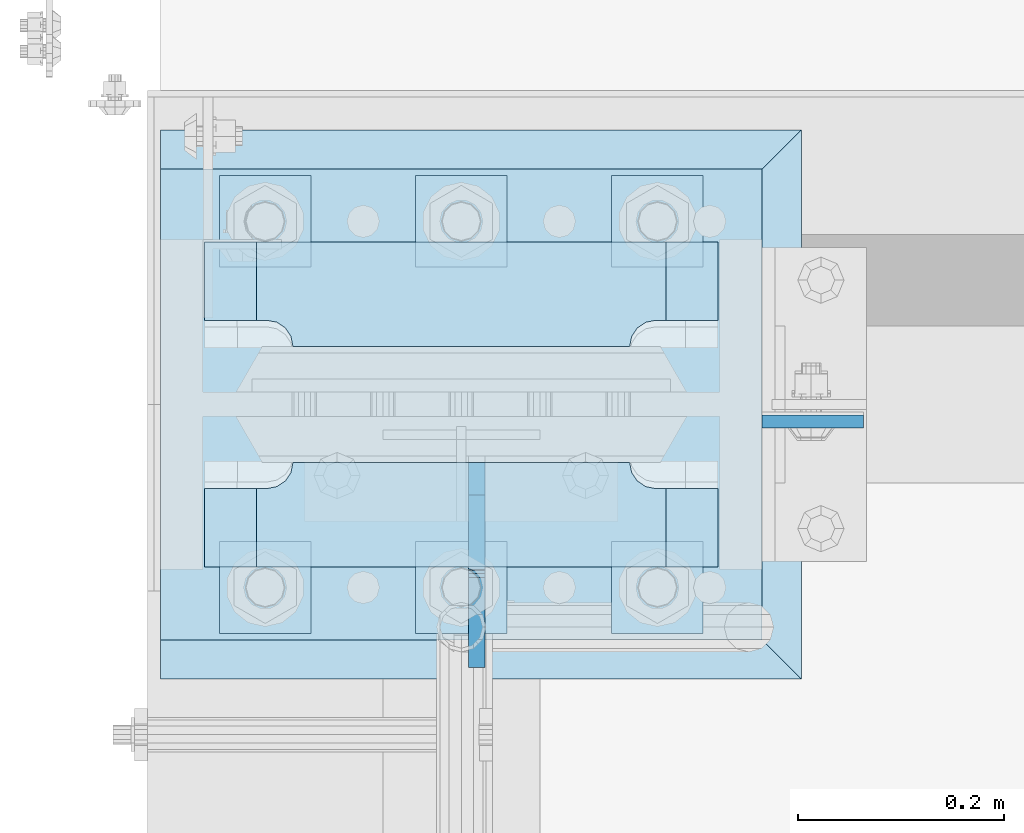
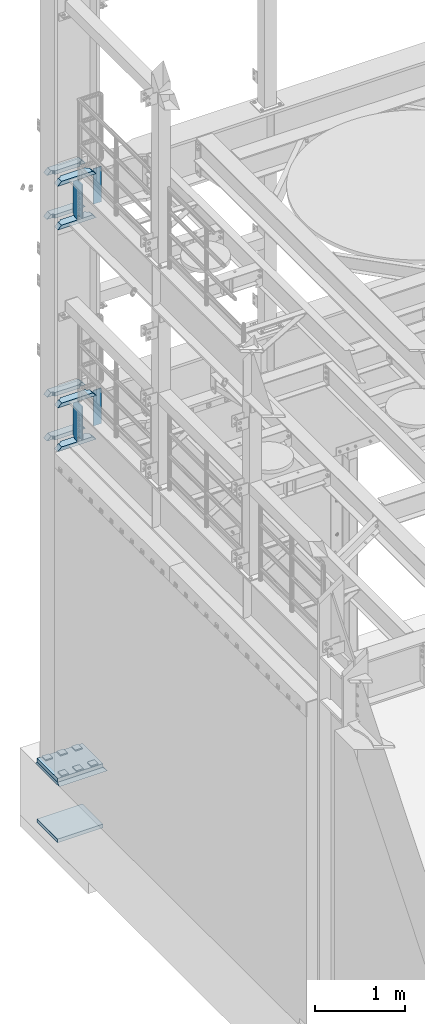
# One storey, part 1773 of 1876: 21 plates, 3 elements without a shape of their own.
"""IFC2X3 building model written with IfcOpenShell, lengths in millimetres."""

from ifc_helpers import new_model, si_unit, frame, origin_with_axes, place, context, subcontext, project, spatial, faceted_brep, material, type_object, element, aggregate, save


model = new_model("IFC2X3")

# Units and contexts
model_context = context("Model", 3, precision=1e-05, world=origin_with_axes())
body_context = subcontext(model_context, "Body", "Model", "MODEL_VIEW")
ifc_project = project(units=[si_unit("LENGTHUNIT", "METRE", prefix="MILLI"), si_unit("AREAUNIT", "SQUARE_METRE"), si_unit("VOLUMEUNIT", "CUBIC_METRE"), si_unit("MASSUNIT", "GRAM", prefix="KILO"), si_unit("TIMEUNIT", "SECOND"), si_unit("PLANEANGLEUNIT", "RADIAN"), si_unit("SOLIDANGLEUNIT", "STERADIAN"), si_unit("THERMODYNAMICTEMPERATUREUNIT", "DEGREE_CELSIUS"), si_unit("LUMINOUSINTENSITYUNIT", "LUMEN")], contexts=[model_context])

# Site, building, storey
site_placement = place(None, origin_with_axes())
site = spatial("IfcSite", under=ifc_project, at=site_placement, CompositionType="ELEMENT")
building_placement = place(site_placement, origin_with_axes())
building = spatial("IfcBuilding", under=site, at=building_placement, Name="Undefined", CompositionType="ELEMENT")
storey_placement = place(building_placement, origin_with_axes())
storey = spatial("IfcBuildingStorey", under=building, at=storey_placement, Name="Undefined", CompositionType="ELEMENT", Elevation=0.0)

# Assembly, plate
assembly_1_placement = place(storey_placement, origin_with_axes())
assembly_1 = element("IfcElementAssembly", 1, at=assembly_1_placement, inside=storey, Name="GROUT", AssemblyPlace="NOTDEFINED", PredefinedType="REINFORCEMENT_UNIT")
ifc_material_1 = material(Name="CONCRETE/Concrete_Undefined")
plate_type_1 = type_object("IfcPlateType", PredefinedType="NOTDEFINED")
plate_1_placement = place(assembly_1_placement, frame((-330.2, 13449.3, 19.05), z_axis=(0.0, 1.0, 0.0), x_axis=(1.0, 0.0, 0.0)))
plate_1 = element("IfcPlate", 2, at=plate_1_placement, type_object=plate_type_1, material=ifc_material_1, Name="GROUT", context=body_context, shape_type="Brep", body=[
    faceted_brep([(38.1, 19.0499984741211, 533.400024414062), (38.1, 19.05, 0.0), (38.1000000120275, -19.05, 38.1000000109725), (38.100000011611, -19.05, 495.299999988873), (622.299999999984, -19.05, 38.1000000000167), (660.400024414062, 19.05, 0.0), (660.400024414062, 19.05, 533.400024414062), (622.299999999999, -19.05, 495.299999999985)], [[[0, 1, 2, 3]], [[4, 5, 6, 7]], [[7, 6, 0, 3]], [[4, 7, 3, 2]], [[5, 4, 2, 1]], [[6, 5, 1, 0]]]),
])
aggregate(assembly_1, [plate_1])

# Assembly, plates
assembly_2_placement = place(storey_placement, origin_with_axes())
assembly_2 = element("IfcElementAssembly", 3, at=assembly_2_placement, inside=storey, Name="COLUMN", AssemblyPlace="NOTDEFINED", PredefinedType="RIGID_FRAME")
ifc_material_2 = material(Name="STEEL/A572-50")
plate_type_2 = type_object("IfcPlateType", PredefinedType="NOTDEFINED")
plate_2_placement = place(assembly_2_placement, frame((292.1, 13699.3320001602, 8070.85), z_axis=(1.0, 0.0, 0.0), x_axis=(0.0, 0.0, -1.0)))
plate_2 = element("IfcPlate", 4, at=plate_2_placement, type_object=plate_type_2, material=ifc_material_2, Name="PLATE", context=body_context, shape_type="Brep", body=[
    faceted_brep([(0.0, -6.35000000000036, 0.0), (0.0, -6.34999999999991, 98.4250030517578), (0.0, 6.34999999999991, 98.4250030517578), (0.0, 6.35000000000036, 0.0), (482.600006103516, -6.35000000000036, 98.4250030517578), (482.600006103516, 6.35000000000036, 98.4250030517578), (482.600006103516, -6.35000000000036, 0.0), (482.600006103516, 6.35000000000036, 0.0)], [[[0, 1, 2, 3]], [[1, 4, 5, 2]], [[4, 6, 7, 5]], [[6, 0, 3, 7]], [[5, 7, 3, 2]], [[6, 4, 1, 0]]]),
])
plate_3_placement = place(assembly_2_placement, frame((292.1, 13699.3320001602, 5048.25), z_axis=(1.0, 0.0, 0.0), x_axis=(0.0, 0.0, -1.0)))
plate_3 = element("IfcPlate", 5, at=plate_3_placement, type_object=plate_type_2, material=ifc_material_2, Name="PLATE", context=body_context, shape_type="Brep", body=[
    faceted_brep([(0.0, -6.35000000000036, 0.0), (0.0, -6.34999999999991, 98.4250030517578), (0.0, 6.34999999999991, 98.4250030517578), (0.0, 6.35000000000036, 0.0), (482.600006103516, -6.35000000000036, 98.4250030517578), (482.600006103516, 6.35000000000036, 98.4250030517578), (482.600006103516, -6.35000000000036, 0.0), (482.600006103516, 6.35000000000036, 0.0)], [[[0, 1, 2, 3]], [[1, 4, 5, 2]], [[4, 6, 7, 5]], [[6, 0, 3, 7]], [[5, 7, 3, 2]], [[6, 4, 1, 0]]]),
])
plate_type_3 = type_object("IfcPlateType", PredefinedType="NOTDEFINED")
plate_4_placement = place(assembly_2_placement, frame((-249.2375, 13772.35625, 7531.10002441406), z_axis=(1.0, 0.0, 0.0), x_axis=(0.0, 1.0, 0.0)))
plate_4 = element("IfcPlate", 6, at=plate_4_placement, type_object=plate_type_3, material=ifc_material_2, Name="PLATE", context=body_context, shape_type="Brep", body=[
    faceted_brep([(101.599998474121, -25.3999999999996, 498.475006103516), (101.599998474121, 25.3999999999996, 447.975004579813), (25.3999996185303, 25.3999999999996, 447.975004579813), (25.3999996185303, -25.3999999999996, 498.475006103516), (23.4665397733534, -25.3999999999996, 428.429848211837), (25.3999996185303, -25.3999999999996, 438.150007247925), (25.3999996185303, 25.3999999999996, 438.150007247925), (23.4665397733534, 25.3999999999996, 428.429848211837), (17.9605119723965, -25.3999999999996, 420.189495275529), (17.9605119723965, 25.3999999999996, 420.189495275529), (9.72015903608917, -25.3999999999996, 414.683467474573), (9.72015903608917, 25.3999999999996, 414.683467474573), (0.0, -25.3999999999996, 412.750007629395), (0.0, 25.3999999999996, 412.750007629395), (0.0, -25.3999999999996, 85.7249984741211), (0.0, 25.3999999999996, 85.7249984741211), (9.72015903609099, -25.3999999999996, 83.7915386289451), (9.72015903609099, 25.3999999999996, 83.7915386289451), (17.9605119723983, -25.3999999999996, 78.2855108279891), (17.9605119723983, 25.3999999999996, 78.2855108279891), (23.4665397733552, -25.3999999999996, 70.0451578916818), (23.4665397733552, 25.3999999999996, 70.0451578916818), (25.3999996185303, -25.3999999999996, 60.3249988555908), (25.3999996185303, 25.3999999999996, 60.3249988555908), (25.3999996185303, 25.3999999999996, 50.5000015237028), (25.3999996185303, -25.3999999999996, 0.0), (101.599998474121, 25.3999999999996, 50.5000015237028), (101.599998474121, -25.3999999999996, 0.0)], [[[0, 1, 2, 3]], [[4, 5, 6, 7]], [[8, 4, 7, 9]], [[10, 8, 9, 11]], [[12, 10, 11, 13]], [[14, 12, 13, 15]], [[16, 14, 15, 17]], [[18, 16, 17, 19]], [[20, 18, 19, 21]], [[22, 20, 21, 23]], [[22, 23, 24, 25]], [[26, 27, 25, 24]], [[5, 4, 8, 10, 12, 14, 16, 18, 20, 22, 25, 27, 0, 3]], [[6, 5, 3, 2]], [[26, 24, 23, 21, 19, 17, 15, 13, 11, 9, 7, 6, 2, 1]], [[27, 26, 1, 0]]]),
])
plate_5_placement = place(assembly_2_placement, frame((-249.2375, 13772.35625, 8128.0), z_axis=(1.0, 0.0, 0.0), x_axis=(0.0, 1.0, 0.0)))
plate_5 = element("IfcPlate", 7, at=plate_5_placement, type_object=plate_type_3, material=ifc_material_2, Name="PLATE", context=body_context, shape_type="Brep", body=[
    faceted_brep([(101.599998474121, -25.3999999999996, 498.475006103516), (101.599998474121, 25.3999999999996, 447.975004579813), (25.3999996185303, 25.3999999999996, 447.975004579813), (25.3999996185303, -25.3999999999996, 498.475006103516), (23.4665397733534, -25.3999999999996, 428.429848211837), (25.3999996185303, -25.3999999999996, 438.150007247925), (25.3999996185303, 25.3999999999996, 438.150007247925), (23.4665397733534, 25.3999999999996, 428.429848211837), (17.9605119723965, -25.3999999999996, 420.189495275529), (17.9605119723965, 25.3999999999996, 420.189495275529), (9.72015903608917, -25.3999999999996, 414.683467474573), (9.72015903608917, 25.3999999999996, 414.683467474573), (0.0, -25.3999999999996, 412.750007629395), (0.0, 25.3999999999996, 412.750007629395), (0.0, -25.3999999999996, 85.7249984741211), (0.0, 25.3999999999996, 85.7249984741211), (9.72015903609099, -25.3999999999996, 83.7915386289451), (9.72015903609099, 25.3999999999996, 83.7915386289451), (17.9605119723983, -25.3999999999996, 78.2855108279891), (17.9605119723983, 25.3999999999996, 78.2855108279891), (23.4665397733552, -25.3999999999996, 70.0451578916818), (23.4665397733552, 25.3999999999996, 70.0451578916818), (25.3999996185303, -25.3999999999996, 60.3249988555908), (25.3999996185303, 25.3999999999996, 60.3249988555908), (25.3999996185303, 25.3999999999996, 50.5000015237028), (25.3999996185303, -25.3999999999996, 0.0), (101.599998474121, 25.3999999999996, 50.5000015237028), (101.599998474121, -25.3999999999996, 0.0)], [[[0, 1, 2, 3]], [[4, 5, 6, 7]], [[8, 4, 7, 9]], [[10, 8, 9, 11]], [[12, 10, 11, 13]], [[14, 12, 13, 15]], [[16, 14, 15, 17]], [[18, 16, 17, 19]], [[20, 18, 19, 21]], [[22, 20, 21, 23]], [[22, 23, 24, 25]], [[26, 27, 25, 24]], [[5, 4, 8, 10, 12, 14, 16, 18, 20, 22, 25, 27, 0, 3]], [[6, 5, 3, 2]], [[26, 24, 23, 21, 19, 17, 15, 13, 11, 9, 7, 6, 2, 1]], [[27, 26, 1, 0]]]),
])
plate_6_placement = place(assembly_2_placement, frame((-249.2375, 13558.04375, 7531.10002441406), z_axis=(1.0, 0.0, 0.0), x_axis=(0.0, 1.0, 0.0)))
plate_6 = element("IfcPlate", 8, at=plate_6_placement, type_object=plate_type_3, material=ifc_material_2, Name="PLATE", context=body_context, shape_type="Brep", body=[
    faceted_brep([(76.1999988555908, -25.3999999999996, 498.475006103516), (76.1999988555908, 25.3999999999996, 447.975004579812), (0.0, 25.3999999999996, 447.975004579812), (0.0, -25.3999999999996, 498.475006103516), (76.1999988555908, 25.3999999999996, 50.5000015237032), (76.1999988555908, -25.3999999999996, 0.0), (0.0, -25.3999996185375, 0.0), (0.0, 25.3999999999996, 50.5000015237032), (76.1999988555908, 25.3999999999996, 60.3249988555908), (76.1999988555908, -25.3999999999996, 60.3249988555908), (78.1334587007668, -25.3999999999996, 70.045157891682), (78.1334587007668, 25.3999999999996, 70.045157891682), (83.6394865017228, -25.3999999999996, 78.2855108279893), (83.6394865017228, 25.3999999999996, 78.2855108279893), (91.8798394380301, -25.3999999999996, 83.7915386289454), (91.8798394380301, 25.3999999999996, 83.7915386289454), (101.599998474121, -25.3999999999996, 85.7249984741211), (101.599998474121, 25.3999999999996, 85.7249984741211), (101.599998474121, -25.3999999999996, 412.750007629395), (101.599998474121, 25.3999999999996, 412.750007629395), (91.8798394380301, -25.3999999999996, 414.68346747457), (91.8798394380301, 25.3999999999996, 414.68346747457), (83.6394865017219, -25.3999999999996, 420.189495275526), (83.6394865017219, 25.3999999999996, 420.189495275526), (78.1334587007659, -25.3999999999996, 428.429848211834), (78.1334587007659, 25.3999999999996, 428.429848211834), (76.1999988555908, -25.3999999999996, 438.150007247925), (76.1999988555908, 25.3999999999996, 438.150007247925)], [[[0, 1, 2, 3]], [[4, 5, 6, 7]], [[8, 9, 5, 4]], [[10, 9, 8, 11]], [[12, 10, 11, 13]], [[14, 12, 13, 15]], [[16, 14, 15, 17]], [[18, 16, 17, 19]], [[20, 18, 19, 21]], [[22, 20, 21, 23]], [[24, 22, 23, 25]], [[26, 24, 25, 27]], [[6, 5, 9, 10, 12, 14, 16, 18, 20, 22, 24, 26, 0, 3]], [[7, 6, 3, 2]], [[27, 25, 23, 21, 19, 17, 15, 13, 11, 8, 4, 7, 2, 1]], [[26, 27, 1, 0]]]),
])
plate_7_placement = place(assembly_2_placement, frame((-249.2375, 13558.04375, 8128.0), z_axis=(1.0, 0.0, 0.0), x_axis=(0.0, 1.0, 0.0)))
plate_7 = element("IfcPlate", 9, at=plate_7_placement, type_object=plate_type_3, material=ifc_material_2, Name="PLATE", context=body_context, shape_type="Brep", body=[
    faceted_brep([(76.1999988555908, -25.3999999999996, 498.475006103516), (76.1999988555908, 25.3999999999996, 447.975004579812), (0.0, 25.3999999999996, 447.975004579812), (0.0, -25.3999999999996, 498.475006103516), (76.1999988555908, 25.3999999999996, 50.5000015237032), (76.1999988555908, -25.3999999999996, 0.0), (0.0, -25.3999996185375, 0.0), (0.0, 25.3999999999996, 50.5000015237032), (76.1999988555908, 25.3999999999996, 60.3249988555908), (76.1999988555908, -25.3999999999996, 60.3249988555908), (78.1334587007668, -25.3999999999996, 70.045157891682), (78.1334587007668, 25.3999999999996, 70.045157891682), (83.6394865017228, -25.3999999999996, 78.2855108279893), (83.6394865017228, 25.3999999999996, 78.2855108279893), (91.8798394380301, -25.3999999999996, 83.7915386289454), (91.8798394380301, 25.3999999999996, 83.7915386289454), (101.599998474121, -25.3999999999996, 85.7249984741211), (101.599998474121, 25.3999999999996, 85.7249984741211), (101.599998474121, -25.3999999999996, 412.750007629395), (101.599998474121, 25.3999999999996, 412.750007629395), (91.8798394380301, -25.3999999999996, 414.68346747457), (91.8798394380301, 25.3999999999996, 414.68346747457), (83.6394865017219, -25.3999999999996, 420.189495275526), (83.6394865017219, 25.3999999999996, 420.189495275526), (78.1334587007659, -25.3999999999996, 428.429848211834), (78.1334587007659, 25.3999999999996, 428.429848211834), (76.1999988555908, -25.3999999999996, 438.150007247925), (76.1999988555908, 25.3999999999996, 438.150007247925)], [[[0, 1, 2, 3]], [[4, 5, 6, 7]], [[8, 9, 5, 4]], [[10, 9, 8, 11]], [[12, 10, 11, 13]], [[14, 12, 13, 15]], [[16, 14, 15, 17]], [[18, 16, 17, 19]], [[20, 18, 19, 21]], [[22, 20, 21, 23]], [[24, 22, 23, 25]], [[26, 24, 25, 27]], [[6, 5, 9, 10, 12, 14, 16, 18, 20, 22, 24, 26, 0, 3]], [[7, 6, 3, 2]], [[27, 25, 23, 21, 19, 17, 15, 13, 11, 8, 4, 7, 2, 1]], [[26, 27, 1, 0]]]),
])
plate_8_placement = place(assembly_2_placement, frame((-249.2375, 13772.35625, 4508.50002441406), z_axis=(1.0, 0.0, 0.0), x_axis=(0.0, 1.0, 0.0)))
plate_8 = element("IfcPlate", 10, at=plate_8_placement, type_object=plate_type_3, material=ifc_material_2, Name="PLATE", context=body_context, shape_type="Brep", body=[
    faceted_brep([(101.599998474121, -25.3999999999996, 498.475006103516), (101.599998474121, 25.3999999999996, 447.975004579813), (25.3999996185303, 25.3999999999996, 447.975004579813), (25.3999996185303, -25.3999999999996, 498.475006103516), (23.4665397733534, -25.3999999999996, 428.429848211837), (25.3999996185303, -25.3999999999996, 438.150007247925), (25.3999996185303, 25.3999999999996, 438.150007247925), (23.4665397733534, 25.3999999999996, 428.429848211837), (17.9605119723965, -25.3999999999996, 420.189495275529), (17.9605119723965, 25.3999999999996, 420.189495275529), (9.72015903608917, -25.3999999999996, 414.683467474573), (9.72015903608917, 25.3999999999996, 414.683467474573), (0.0, -25.3999999999996, 412.750007629395), (0.0, 25.3999999999996, 412.750007629395), (0.0, -25.3999999999996, 85.7249984741211), (0.0, 25.3999999999996, 85.7249984741211), (9.72015903609099, -25.3999999999996, 83.7915386289451), (9.72015903609099, 25.3999999999996, 83.7915386289451), (17.9605119723983, -25.3999999999996, 78.2855108279891), (17.9605119723983, 25.3999999999996, 78.2855108279891), (23.4665397733552, -25.3999999999996, 70.0451578916818), (23.4665397733552, 25.3999999999996, 70.0451578916818), (25.3999996185303, -25.3999999999996, 60.3249988555908), (25.3999996185303, 25.3999999999996, 60.3249988555908), (25.3999996185303, 25.3999999999996, 50.5000015237028), (25.3999996185303, -25.3999999999996, 0.0), (101.599998474121, 25.3999999999996, 50.5000015237028), (101.599998474121, -25.3999999999996, 0.0)], [[[0, 1, 2, 3]], [[4, 5, 6, 7]], [[8, 4, 7, 9]], [[10, 8, 9, 11]], [[12, 10, 11, 13]], [[14, 12, 13, 15]], [[16, 14, 15, 17]], [[18, 16, 17, 19]], [[20, 18, 19, 21]], [[22, 20, 21, 23]], [[22, 23, 24, 25]], [[26, 27, 25, 24]], [[5, 4, 8, 10, 12, 14, 16, 18, 20, 22, 25, 27, 0, 3]], [[6, 5, 3, 2]], [[26, 24, 23, 21, 19, 17, 15, 13, 11, 9, 7, 6, 2, 1]], [[27, 26, 1, 0]]]),
])
plate_9_placement = place(assembly_2_placement, frame((-249.2375, 13772.35625, 5105.4), z_axis=(1.0, 0.0, 0.0), x_axis=(0.0, 1.0, 0.0)))
plate_9 = element("IfcPlate", 11, at=plate_9_placement, type_object=plate_type_3, material=ifc_material_2, Name="PLATE", context=body_context, shape_type="Brep", body=[
    faceted_brep([(101.599998474121, -25.3999999999996, 498.475006103516), (101.599998474121, 25.3999999999996, 447.975004579813), (25.3999996185303, 25.3999999999996, 447.975004579813), (25.3999996185303, -25.3999999999996, 498.475006103516), (23.4665397733534, -25.3999999999996, 428.429848211837), (25.3999996185303, -25.3999999999996, 438.150007247925), (25.3999996185303, 25.3999999999996, 438.150007247925), (23.4665397733534, 25.3999999999996, 428.429848211837), (17.9605119723965, -25.3999999999996, 420.189495275529), (17.9605119723965, 25.3999999999996, 420.189495275529), (9.72015903608917, -25.3999999999996, 414.683467474573), (9.72015903608917, 25.3999999999996, 414.683467474573), (0.0, -25.3999999999996, 412.750007629395), (0.0, 25.3999999999996, 412.750007629395), (0.0, -25.3999999999996, 85.7249984741211), (0.0, 25.3999999999996, 85.7249984741211), (9.72015903609099, -25.3999999999996, 83.7915386289451), (9.72015903609099, 25.3999999999996, 83.7915386289451), (17.9605119723983, -25.3999999999996, 78.2855108279891), (17.9605119723983, 25.3999999999996, 78.2855108279891), (23.4665397733552, -25.3999999999996, 70.0451578916818), (23.4665397733552, 25.3999999999996, 70.0451578916818), (25.3999996185303, -25.3999999999996, 60.3249988555908), (25.3999996185303, 25.3999999999996, 60.3249988555908), (25.3999996185303, 25.3999999999996, 50.5000015237028), (25.3999996185303, -25.3999999999996, 0.0), (101.599998474121, 25.3999999999996, 50.5000015237028), (101.599998474121, -25.3999999999996, 0.0)], [[[0, 1, 2, 3]], [[4, 5, 6, 7]], [[8, 4, 7, 9]], [[10, 8, 9, 11]], [[12, 10, 11, 13]], [[14, 12, 13, 15]], [[16, 14, 15, 17]], [[18, 16, 17, 19]], [[20, 18, 19, 21]], [[22, 20, 21, 23]], [[22, 23, 24, 25]], [[26, 27, 25, 24]], [[5, 4, 8, 10, 12, 14, 16, 18, 20, 22, 25, 27, 0, 3]], [[6, 5, 3, 2]], [[26, 24, 23, 21, 19, 17, 15, 13, 11, 9, 7, 6, 2, 1]], [[27, 26, 1, 0]]]),
])
plate_10_placement = place(assembly_2_placement, frame((-249.2375, 13558.04375, 4508.50002441406), z_axis=(1.0, 0.0, 0.0), x_axis=(0.0, 1.0, 0.0)))
plate_10 = element("IfcPlate", 12, at=plate_10_placement, type_object=plate_type_3, material=ifc_material_2, Name="PLATE", context=body_context, shape_type="Brep", body=[
    faceted_brep([(76.1999988555908, -25.3999999999996, 498.475006103516), (76.1999988555908, 25.3999999999996, 447.975004579812), (0.0, 25.3999999999996, 447.975004579812), (0.0, -25.3999999999996, 498.475006103516), (76.1999988555908, 25.3999999999996, 50.5000015237032), (76.1999988555908, -25.3999999999996, 0.0), (0.0, -25.3999996185375, 0.0), (0.0, 25.3999999999996, 50.5000015237032), (76.1999988555908, 25.3999999999996, 60.3249988555908), (76.1999988555908, -25.3999999999996, 60.3249988555908), (78.1334587007668, -25.3999999999996, 70.045157891682), (78.1334587007668, 25.3999999999996, 70.045157891682), (83.6394865017228, -25.3999999999996, 78.2855108279893), (83.6394865017228, 25.3999999999996, 78.2855108279893), (91.8798394380301, -25.3999999999996, 83.7915386289454), (91.8798394380301, 25.3999999999996, 83.7915386289454), (101.599998474121, -25.3999999999996, 85.7249984741211), (101.599998474121, 25.3999999999996, 85.7249984741211), (101.599998474121, -25.3999999999996, 412.750007629395), (101.599998474121, 25.3999999999996, 412.750007629395), (91.8798394380301, -25.3999999999996, 414.68346747457), (91.8798394380301, 25.3999999999996, 414.68346747457), (83.6394865017219, -25.3999999999996, 420.189495275526), (83.6394865017219, 25.3999999999996, 420.189495275526), (78.1334587007659, -25.3999999999996, 428.429848211834), (78.1334587007659, 25.3999999999996, 428.429848211834), (76.1999988555908, -25.3999999999996, 438.150007247925), (76.1999988555908, 25.3999999999996, 438.150007247925)], [[[0, 1, 2, 3]], [[4, 5, 6, 7]], [[8, 9, 5, 4]], [[10, 9, 8, 11]], [[12, 10, 11, 13]], [[14, 12, 13, 15]], [[16, 14, 15, 17]], [[18, 16, 17, 19]], [[20, 18, 19, 21]], [[22, 20, 21, 23]], [[24, 22, 23, 25]], [[26, 24, 25, 27]], [[6, 5, 9, 10, 12, 14, 16, 18, 20, 22, 24, 26, 0, 3]], [[7, 6, 3, 2]], [[27, 25, 23, 21, 19, 17, 15, 13, 11, 8, 4, 7, 2, 1]], [[26, 27, 1, 0]]]),
])
plate_11_placement = place(assembly_2_placement, frame((-249.2375, 13558.04375, 5105.4), z_axis=(1.0, 0.0, 0.0), x_axis=(0.0, 1.0, 0.0)))
plate_11 = element("IfcPlate", 13, at=plate_11_placement, type_object=plate_type_3, material=ifc_material_2, Name="PLATE", context=body_context, shape_type="Brep", body=[
    faceted_brep([(76.1999988555908, -25.3999999999996, 498.475006103516), (76.1999988555908, 25.3999999999996, 447.975004579812), (0.0, 25.3999999999996, 447.975004579812), (0.0, -25.3999999999996, 498.475006103516), (76.1999988555908, 25.3999999999996, 50.5000015237032), (76.1999988555908, -25.3999999999996, 0.0), (0.0, -25.3999996185375, 0.0), (0.0, 25.3999999999996, 50.5000015237032), (76.1999988555908, 25.3999999999996, 60.3249988555908), (76.1999988555908, -25.3999999999996, 60.3249988555908), (78.1334587007668, -25.3999999999996, 70.045157891682), (78.1334587007668, 25.3999999999996, 70.045157891682), (83.6394865017228, -25.3999999999996, 78.2855108279893), (83.6394865017228, 25.3999999999996, 78.2855108279893), (91.8798394380301, -25.3999999999996, 83.7915386289454), (91.8798394380301, 25.3999999999996, 83.7915386289454), (101.599998474121, -25.3999999999996, 85.7249984741211), (101.599998474121, 25.3999999999996, 85.7249984741211), (101.599998474121, -25.3999999999996, 412.750007629395), (101.599998474121, 25.3999999999996, 412.750007629395), (91.8798394380301, -25.3999999999996, 414.68346747457), (91.8798394380301, 25.3999999999996, 414.68346747457), (83.6394865017219, -25.3999999999996, 420.189495275526), (83.6394865017219, 25.3999999999996, 420.189495275526), (78.1334587007659, -25.3999999999996, 428.429848211834), (78.1334587007659, 25.3999999999996, 428.429848211834), (76.1999988555908, -25.3999999999996, 438.150007247925), (76.1999988555908, 25.3999999999996, 438.150007247925)], [[[0, 1, 2, 3]], [[4, 5, 6, 7]], [[8, 9, 5, 4]], [[10, 9, 8, 11]], [[12, 10, 11, 13]], [[14, 12, 13, 15]], [[16, 14, 15, 17]], [[18, 16, 17, 19]], [[20, 18, 19, 21]], [[22, 20, 21, 23]], [[24, 22, 23, 25]], [[26, 24, 25, 27]], [[6, 5, 9, 10, 12, 14, 16, 18, 20, 22, 24, 26, 0, 3]], [[7, 6, 3, 2]], [[27, 25, 23, 21, 19, 17, 15, 13, 11, 8, 4, 7, 2, 1]], [[26, 27, 1, 0]]]),
])
ifc_material_3 = material(Name="STEEL/A36")
plate_type_4 = type_object("IfcPlateType", PredefinedType="NOTDEFINED")
plate_12_placement = place(assembly_2_placement, frame((15.080500125885, 13659.64375, 8102.6), z_axis=(0.0, -1.0, 0.0), x_axis=(0.0, 0.0, -1.0)))
plate_12 = element("IfcPlate", 14, at=plate_12_placement, type_object=plate_type_4, material=ifc_material_3, Name="PLATE", context=body_context, shape_type="Brep", body=[
    faceted_brep([(469.900012207031, -7.9375, 199.231247384208), (469.900012207031, -7.9375, 116.681246757507), (469.900012207031, 7.9375, 116.681246757507), (469.900012207031, 7.9375, 199.231246948242), (470.866742129619, -7.9375, 111.821167239462), (470.866742129619, 7.9375, 111.821167239462), (473.619756030097, -7.9375, 107.700990771308), (473.619756030097, 7.9375, 107.700990771308), (477.739932498251, -7.9375, 104.94797687083), (477.739932498251, 7.9375, 104.94797687083), (482.600012016296, -7.9375, 103.981246948242), (482.600012016296, 7.9375, 103.981246948242), (546.099975585938, -7.9375, 103.981246948242), (546.099975585938, 7.9375, 103.981246948242), (12.6999996185305, -7.9375, 199.231249999999), (12.6999996185305, 7.9375, 199.231246948242), (12.6999996185305, 7.9375, 116.681249809264), (12.6999996185305, -7.9375, 116.681249809264), (11.7332696959429, 7.9375, 111.821170291219), (11.7332696959429, -7.9375, 111.821170291219), (8.98025579546447, 7.9375, 107.700993823065), (8.98025579546447, -7.9375, 107.700993823065), (4.86007932731081, 7.9375, 104.947979922586), (4.86007932731081, -7.9375, 104.947979922586), (0.0, 7.9375, 103.981249999999), (0.0, -7.9375, 103.981249999999), (0.0, 7.93749999999999, 31.75), (0.0, -7.93749999999998, 31.75), (31.75, -7.93749999999998, 0.0), (31.75, 7.93749999999999, 0.0), (514.349975585938, -7.9375, 0.0), (514.349975585938, 7.9375, 0.0), (546.099975585938, -7.9375, 31.75), (546.099975585938, 7.9375, 31.75)], [[[0, 1, 2, 3]], [[4, 5, 2, 1]], [[6, 7, 5, 4]], [[8, 9, 7, 6]], [[10, 11, 9, 8]], [[12, 13, 11, 10]], [[14, 15, 16, 17]], [[17, 16, 18, 19]], [[19, 18, 20, 21]], [[21, 20, 22, 23]], [[23, 22, 24, 25]], [[26, 27, 25, 24]], [[28, 27, 26, 29]], [[30, 28, 29, 31]], [[32, 30, 31, 33]], [[8, 6, 4, 1, 0, 14, 17, 19, 21, 23, 25, 27, 28, 30, 32, 12, 10]], [[15, 14, 0, 3]], [[33, 31, 29, 26, 24, 22, 20, 18, 16, 15, 3, 2, 5, 7, 9, 11, 13]], [[32, 33, 13, 12]]]),
])
plate_13_placement = place(assembly_2_placement, frame((15.080500125885, 13659.64375, 5080.0), z_axis=(0.0, -1.0, 0.0), x_axis=(0.0, 0.0, -1.0)))
plate_13 = element("IfcPlate", 15, at=plate_13_placement, type_object=plate_type_4, material=ifc_material_3, Name="PLATE", context=body_context, shape_type="Brep", body=[
    faceted_brep([(469.900012207031, -7.9375, 199.231247384208), (469.900012207031, -7.9375, 116.681246757507), (469.900012207031, 7.9375, 116.681246757507), (469.900012207031, 7.9375, 199.231246948242), (470.866742129619, -7.9375, 111.821167239462), (470.866742129619, 7.9375, 111.821167239462), (473.619756030097, -7.9375, 107.700990771308), (473.619756030097, 7.9375, 107.700990771308), (477.739932498251, -7.9375, 104.94797687083), (477.739932498251, 7.9375, 104.94797687083), (482.600012016296, -7.9375, 103.981246948242), (482.600012016296, 7.9375, 103.981246948242), (546.099975585938, -7.9375, 103.981246948242), (546.099975585938, 7.9375, 103.981246948242), (12.6999996185305, -7.9375, 199.231249999999), (12.6999996185305, 7.9375, 199.231246948242), (12.6999996185305, 7.9375, 116.681249809264), (12.6999996185305, -7.9375, 116.681249809264), (11.7332696959429, 7.9375, 111.821170291219), (11.7332696959429, -7.9375, 111.821170291219), (8.98025579546447, 7.9375, 107.700993823065), (8.98025579546447, -7.9375, 107.700993823065), (4.86007932731081, 7.9375, 104.947979922586), (4.86007932731081, -7.9375, 104.947979922586), (0.0, 7.9375, 103.981249999999), (0.0, -7.9375, 103.981249999999), (0.0, 7.93749999999999, 31.75), (0.0, -7.93749999999998, 31.75), (31.75, -7.93749999999998, 0.0), (31.75, 7.93749999999999, 0.0), (514.349975585938, -7.9375, 0.0), (514.349975585938, 7.9375, 0.0), (546.099975585938, -7.9375, 31.75), (546.099975585938, 7.9375, 31.75)], [[[0, 1, 2, 3]], [[4, 5, 2, 1]], [[6, 7, 5, 4]], [[8, 9, 7, 6]], [[10, 11, 9, 8]], [[12, 13, 11, 10]], [[14, 15, 16, 17]], [[17, 16, 18, 19]], [[19, 18, 20, 21]], [[21, 20, 22, 23]], [[23, 22, 24, 25]], [[26, 27, 25, 24]], [[28, 27, 26, 29]], [[30, 28, 29, 31]], [[32, 30, 31, 33]], [[8, 6, 4, 1, 0, 14, 17, 19, 21, 23, 25, 27, 28, 30, 32, 12, 10]], [[15, 14, 0, 3]], [[33, 31, 29, 26, 24, 22, 20, 18, 16, 15, 3, 2, 5, 7, 9, 11, 13]], [[32, 33, 13, 12]]]),
])

assembly_3_placement = place(storey_placement, origin_with_axes())
assembly_3 = element("IfcElementAssembly", 16, at=assembly_3_placement, inside=storey, Name="TEMPLATE", AssemblyPlace="NOTDEFINED", PredefinedType="RIGID_FRAME")
plate_type_5 = type_object("IfcPlateType", PredefinedType="NOTDEFINED")
plate_14_placement = place(assembly_3_placement, frame((146.05, 13582.65, 96.8375), z_axis=(0.0, -1.0, 0.0), x_axis=(1.0, 0.0, 0.0)))
plate_14 = element("IfcPlate", 17, at=plate_14_placement, type_object=plate_type_5, material=ifc_material_2, Name="PLATE WASHER", context=body_context, shape_type="Brep", body=[
    faceted_brep([(0.0, -7.9375, 0.0), (0.0, -7.9375, 88.9000015258789), (0.0, 7.9375, 88.9000015258789), (0.0, 7.9375, 0.0), (88.9000015258789, -7.9375, 88.9000015258789), (88.9000015258789, 7.9375, 88.9000015258789), (88.9000015258789, -7.9375, 0.0), (88.9000015258789, 7.9375, 0.0)], [[[0, 1, 2, 3]], [[1, 4, 5, 2]], [[4, 6, 7, 5]], [[6, 0, 3, 7]], [[5, 7, 3, 2]], [[6, 4, 1, 0]]]),
])
plate_15_placement = place(assembly_3_placement, frame((146.05, 13938.25, 96.8375), z_axis=(0.0, -1.0, 0.0), x_axis=(1.0, 0.0, 0.0)))
plate_15 = element("IfcPlate", 18, at=plate_15_placement, type_object=plate_type_5, material=ifc_material_2, Name="PLATE WASHER", context=body_context, shape_type="Brep", body=[
    faceted_brep([(0.0, -7.9375, 0.0), (0.0, -7.9375, 88.9000015258789), (0.0, 7.9375, 88.9000015258789), (0.0, 7.9375, 0.0), (88.9000015258789, -7.9375, 88.9000015258789), (88.9000015258789, 7.9375, 88.9000015258789), (88.9000015258789, -7.9375, 0.0), (88.9000015258789, 7.9375, 0.0)], [[[0, 1, 2, 3]], [[1, 4, 5, 2]], [[4, 6, 7, 5]], [[6, 0, 3, 7]], [[5, 7, 3, 2]], [[6, 4, 1, 0]]]),
])
plate_16_placement = place(assembly_3_placement, frame((-44.45, 13582.65, 96.8375), z_axis=(0.0, -1.0, 0.0), x_axis=(1.0, 0.0, 0.0)))
plate_16 = element("IfcPlate", 19, at=plate_16_placement, type_object=plate_type_5, material=ifc_material_2, Name="PLATE WASHER", context=body_context, shape_type="Brep", body=[
    faceted_brep([(0.0, -7.9375, 0.0), (0.0, -7.9375, 88.9000015258789), (0.0, 7.9375, 88.9000015258789), (0.0, 7.9375, 0.0), (88.9000015258789, -7.9375, 88.9000015258789), (88.9000015258789, 7.9375, 88.9000015258789), (88.9000015258789, -7.9375, 0.0), (88.9000015258789, 7.9375, 0.0)], [[[0, 1, 2, 3]], [[1, 4, 5, 2]], [[4, 6, 7, 5]], [[6, 0, 3, 7]], [[5, 7, 3, 2]], [[6, 4, 1, 0]]]),
])
plate_17_placement = place(assembly_3_placement, frame((-44.45, 13938.25, 96.8375), z_axis=(0.0, -1.0, 0.0), x_axis=(1.0, 0.0, 0.0)))
plate_17 = element("IfcPlate", 20, at=plate_17_placement, type_object=plate_type_5, material=ifc_material_2, Name="PLATE WASHER", context=body_context, shape_type="Brep", body=[
    faceted_brep([(0.0, -7.9375, 0.0), (0.0, -7.9375, 88.9000015258789), (0.0, 7.9375, 88.9000015258789), (0.0, 7.9375, 0.0), (88.9000015258789, -7.9375, 88.9000015258789), (88.9000015258789, 7.9375, 88.9000015258789), (88.9000015258789, -7.9375, 0.0), (88.9000015258789, 7.9375, 0.0)], [[[0, 1, 2, 3]], [[1, 4, 5, 2]], [[4, 6, 7, 5]], [[6, 0, 3, 7]], [[5, 7, 3, 2]], [[6, 4, 1, 0]]]),
])
plate_18_placement = place(assembly_3_placement, frame((-234.95, 13582.65, 96.8375), z_axis=(0.0, -1.0, 0.0), x_axis=(1.0, 0.0, 0.0)))
plate_18 = element("IfcPlate", 21, at=plate_18_placement, type_object=plate_type_5, material=ifc_material_2, Name="PLATE WASHER", context=body_context, shape_type="Brep", body=[
    faceted_brep([(0.0, -7.9375, 0.0), (0.0, -7.9375, 88.9000015258789), (0.0, 7.9375, 88.9000015258789), (0.0, 7.9375, 0.0), (88.9000015258789, -7.9375, 88.9000015258789), (88.9000015258789, 7.9375, 88.9000015258789), (88.9000015258789, -7.9375, 0.0), (88.9000015258789, 7.9375, 0.0)], [[[0, 1, 2, 3]], [[1, 4, 5, 2]], [[4, 6, 7, 5]], [[6, 0, 3, 7]], [[5, 7, 3, 2]], [[6, 4, 1, 0]]]),
])
plate_19_placement = place(assembly_3_placement, frame((-234.95, 13938.25, 96.8375), z_axis=(0.0, -1.0, 0.0), x_axis=(1.0, 0.0, 0.0)))
plate_19 = element("IfcPlate", 22, at=plate_19_placement, type_object=plate_type_5, material=ifc_material_2, Name="PLATE WASHER", context=body_context, shape_type="Brep", body=[
    faceted_brep([(0.0, -7.9375, 0.0), (0.0, -7.9375, 88.9000015258789), (0.0, 7.9375, 88.9000015258789), (0.0, 7.9375, 0.0), (88.9000015258789, -7.9375, 88.9000015258789), (88.9000015258789, 7.9375, 88.9000015258789), (88.9000015258789, -7.9375, 0.0), (88.9000015258789, 7.9375, 0.0)], [[[0, 1, 2, 3]], [[1, 4, 5, 2]], [[4, 6, 7, 5]], [[6, 0, 3, 7]], [[5, 7, 3, 2]], [[6, 4, 1, 0]]]),
])
plate_type_6 = type_object("IfcPlateType", PredefinedType="NOTDEFINED")
plate_20_placement = place(assembly_3_placement, frame((-292.1, 13487.4, -762.0), z_axis=(0.0, 1.0, 0.0), x_axis=(1.0, 0.0, 0.0)))
plate_20 = element("IfcPlate", 23, at=plate_20_placement, type_object=plate_type_6, material=ifc_material_2, Name="PLATE", context=body_context, shape_type="Brep", body=[
    faceted_brep([(0.0, -25.3999996185375, 0.0), (0.0, -25.4, 457.200012207031), (0.0, 25.4, 457.200012207031), (0.0, 25.3999996185339, 9.09494701772928e-13), (584.200012207031, -25.4, 457.200012207031), (584.200012207031, 25.4, 457.200012207031), (584.200012207031, -25.4, 0.0), (584.200012207031, 25.4, 0.0)], [[[0, 1, 2, 3]], [[1, 4, 5, 2]], [[4, 6, 7, 5]], [[6, 0, 3, 7]], [[5, 7, 3, 2]], [[6, 4, 1, 0]]]),
])
aggregate(assembly_3, [plate_20, plate_14, plate_15, plate_16, plate_17, plate_18, plate_19])

# Plate
ifc_material_4 = material(Name="STEEL/A572-GR.50")
plate_21_placement = place(assembly_2_placement, frame((-292.1, 13487.4, 63.5), z_axis=(0.0, 1.0, 0.0), x_axis=(1.0, 0.0, 0.0)))
plate_21 = element("IfcPlate", 24, at=plate_21_placement, type_object=plate_type_6, material=ifc_material_4, Name="PLATE", context=body_context, shape_type="Brep", body=[
    faceted_brep([(0.0, -25.3999996185375, 0.0), (0.0, -25.4, 457.200012207031), (0.0, 25.4, 457.200012207031), (0.0, 25.3999996185339, 9.09494701772928e-13), (584.200012207031, -25.4, 457.200012207031), (584.200012207031, 25.4, 457.200012207031), (584.200012207031, -25.4, 0.0), (584.200012207031, 25.4, 0.0)], [[[0, 1, 2, 3]], [[1, 4, 5, 2]], [[4, 6, 7, 5]], [[6, 0, 3, 7]], [[5, 7, 3, 2]], [[6, 4, 1, 0]]]),
])

aggregate(assembly_2, [plate_4, plate_5, plate_6, plate_7, plate_12, plate_2, plate_8, plate_9, plate_10, plate_11, plate_13, plate_3, plate_21])

save(model, "model.ifc")
